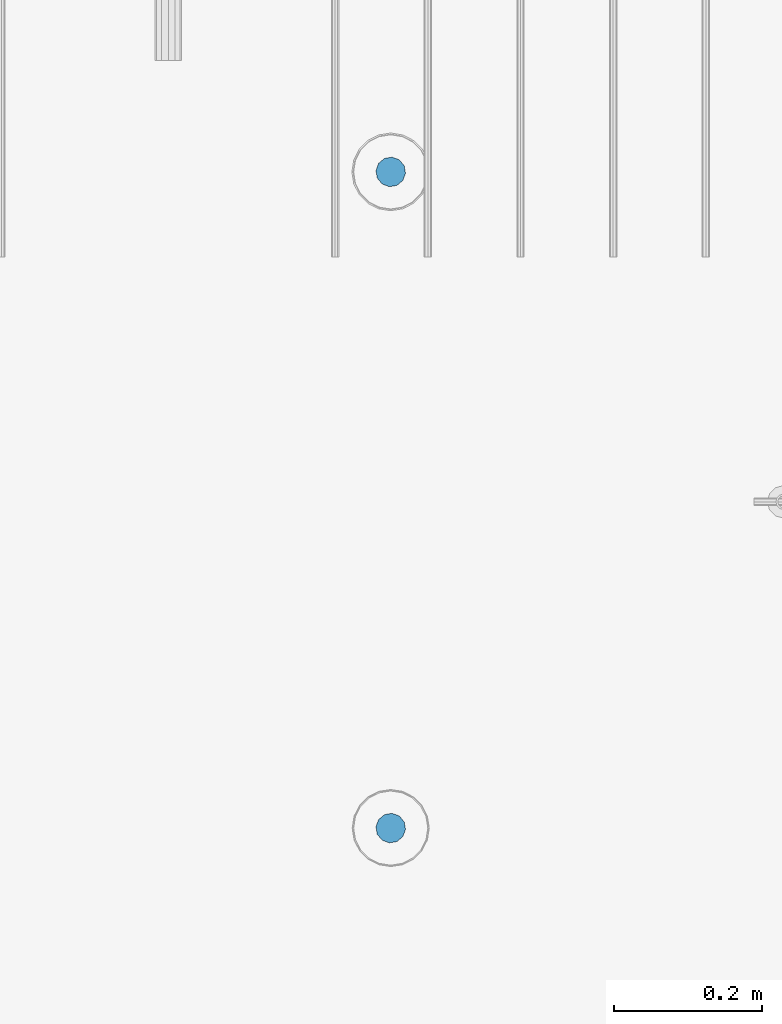
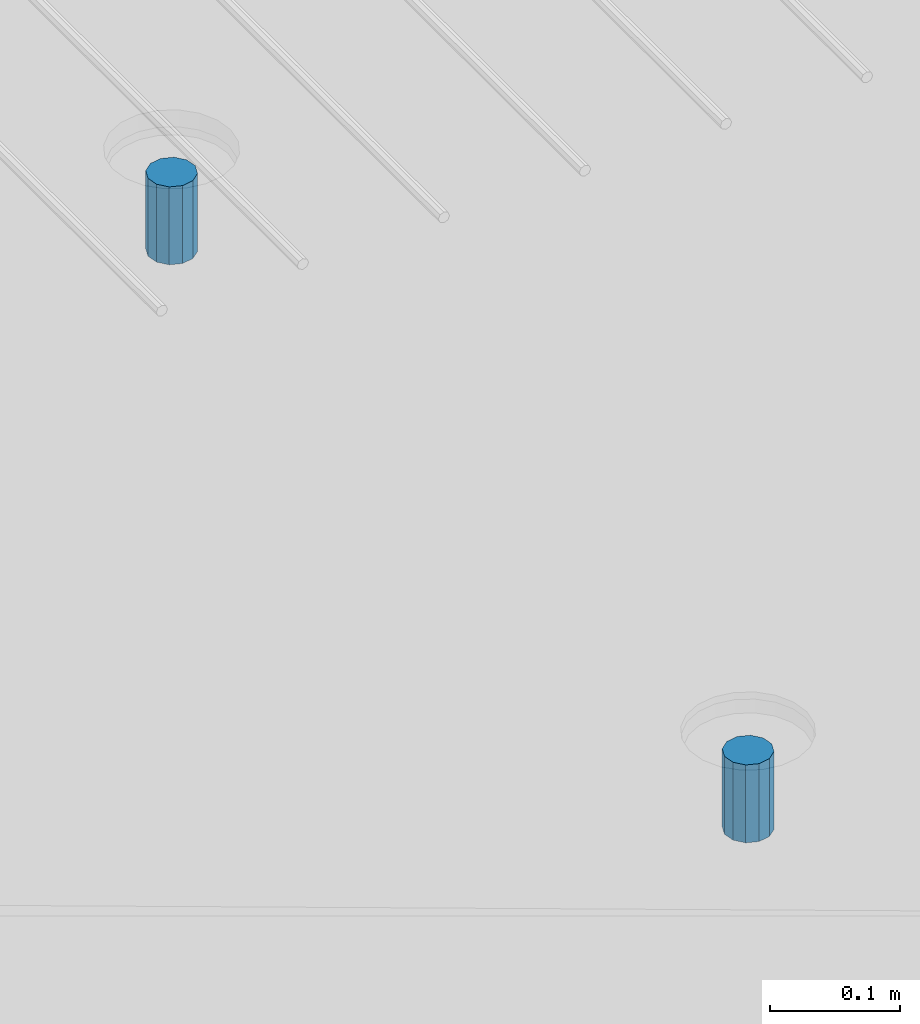
# One storey, part 52 of 350: 2 columns, 3 elements without a shape of their own.
"""IFC2X3 building model written with IfcOpenShell, lengths in millimetres."""

from ifc_helpers import new_model, si_unit, frame, origin_with_axes, place, context, subcontext, project, spatial, faceted_brep, material, type_object, element, aggregate, save


model = new_model("IFC2X3")

# Units and contexts
model_context = context("Model", 3, precision=1e-05, world=origin_with_axes())
body_context = subcontext(model_context, "Body", "Model", "MODEL_VIEW")
ifc_project = project(units=[si_unit("LENGTHUNIT", "METRE", prefix="MILLI"), si_unit("AREAUNIT", "SQUARE_METRE"), si_unit("VOLUMEUNIT", "CUBIC_METRE"), si_unit("MASSUNIT", "GRAM", prefix="KILO"), si_unit("TIMEUNIT", "SECOND"), si_unit("PLANEANGLEUNIT", "RADIAN"), si_unit("SOLIDANGLEUNIT", "STERADIAN"), si_unit("THERMODYNAMICTEMPERATUREUNIT", "DEGREE_CELSIUS"), si_unit("LUMINOUSINTENSITYUNIT", "LUMEN")], contexts=[model_context])

# Site, building, storey
site_placement = place(None, origin_with_axes())
site = spatial("IfcSite", under=ifc_project, at=site_placement, CompositionType="ELEMENT")
building_placement = place(site_placement, origin_with_axes())
building = spatial("IfcBuilding", under=site, at=building_placement, CompositionType="ELEMENT")
storey_placement = place(building_placement, origin_with_axes())
storey = spatial("IfcBuildingStorey", under=building, at=storey_placement, Name="2", CompositionType="ELEMENT", Elevation=0.0)

# Assemblies, columns
assembly_1_placement = place(storey_placement, origin_with_axes())
assembly_1 = element("IfcElementAssembly", 1, at=assembly_1_placement, inside=storey, AssemblyPlace="NOTDEFINED", PredefinedType="REINFORCEMENT_UNIT")
assembly_2_placement = place(assembly_1_placement, origin_with_axes())
assembly_2 = element("IfcElementAssembly", 2, at=assembly_2_placement, Name="Steel Assembly", AssemblyPlace="NOTDEFINED", PredefinedType="RIGID_FRAME")
ifc_material = material(Name="STEEL/Steel_Undefined")
column_type = type_object("IfcColumnType", Name="D40", PredefinedType="NOTDEFINED")
column_1_placement = place(assembly_2_placement, frame((29319.9998566724, 6144.99747289933, 87625.0000000001), z_axis=(0.418944694779052, -0.908011752521126, 0.0), x_axis=(0.0, 0.0, 1.0)))
column_1 = element("IfcColumn", 3, at=column_1_placement, type_object=column_type, material=ifc_material, Name="R-Group R", ObjectType="D40", context=body_context, shape_type="Brep", body=[
    faceted_brep([(0.0, -20.0, 0.0), (0.0, -17.3205080756888, -10.0), (73.0, -17.3205080756852, -9.99999999999636), (73.0, -19.9999999999964, 3.63797880709171e-12), (0.0, -10.0, -17.3205080756888), (73.0, -10.0, -17.3205080756834), (0.0, 0.0, -20.0), (73.0, 3.63797880709171e-12, -19.9999999999964), (0.0, 10.0, -17.3205080756888), (73.0, 10.0000000000036, -17.3205080756834), (0.0, 17.3205080756888, -10.0), (73.0, 17.3205080756925, -9.99999999999818), (0.0, 20.0, 0.0), (73.0, 20.0, 3.63797880709171e-12), (0.0, 17.3205080756888, 10.0), (73.0, 17.3205080756888, 10.0000000000036), (0.0, 10.0, 17.3205080756888), (73.0, 10.0000000000036, 17.3205080756961), (0.0, 0.0, 20.0), (73.0, 3.63797880709171e-12, 20.0000000000036), (0.0, -10.0, 17.3205080756888), (73.0, -9.99999999999636, 17.3205080756925), (0.0, -17.3205080756888, 10.0), (73.0, -17.3205080756852, 10.0000000000055)], [[[0, 1, 2, 3]], [[1, 4, 5, 2]], [[4, 6, 7, 5]], [[6, 8, 9, 7]], [[8, 10, 11, 9]], [[10, 12, 13, 11]], [[12, 14, 15, 13]], [[14, 16, 17, 15]], [[16, 18, 19, 17]], [[18, 20, 21, 19]], [[20, 22, 23, 21]], [[22, 0, 3, 23]], [[5, 7, 9, 11, 13, 15, 17, 19, 21, 23, 3, 2]], [[22, 20, 18, 16, 14, 12, 10, 8, 6, 4, 1, 0]]]),
])
aggregate(assembly_2, [column_1])
assembly_3_placement = place(assembly_1_placement, origin_with_axes())
assembly_3 = element("IfcElementAssembly", 4, at=assembly_3_placement, Name="Steel Assembly", AssemblyPlace="NOTDEFINED", PredefinedType="RIGID_FRAME")
aggregate(assembly_1, [assembly_2, assembly_3])
column_2_placement = place(assembly_3_placement, frame((29319.9998566724, 7029.99747289932, 87630.0000000001), z_axis=(0.418944694779052, -0.908011752521126, 0.0), x_axis=(0.0, 0.0, 1.0)))
column_2 = element("IfcColumn", 5, at=column_2_placement, type_object=column_type, material=ifc_material, Name="R-Group R", ObjectType="D40", context=body_context, shape_type="Brep", body=[
    faceted_brep([(0.0, -20.0, 0.0), (0.0, -17.3205080756888, -10.0), (73.0, -17.3205080756852, -9.99999999999636), (73.0, -19.9999999999964, 3.63797880709171e-12), (0.0, -10.0, -17.3205080756888), (73.0, -10.0, -17.3205080756834), (0.0, 0.0, -20.0), (73.0, 3.63797880709171e-12, -19.9999999999964), (0.0, 10.0, -17.3205080756888), (73.0, 10.0000000000036, -17.3205080756834), (0.0, 17.3205080756888, -10.0), (73.0, 17.3205080756925, -9.99999999999818), (0.0, 20.0, 0.0), (73.0, 20.0, 3.63797880709171e-12), (0.0, 17.3205080756888, 10.0), (73.0, 17.3205080756888, 10.0000000000036), (0.0, 10.0, 17.3205080756888), (73.0, 10.0000000000036, 17.3205080756961), (0.0, 0.0, 20.0), (73.0, 3.63797880709171e-12, 20.0000000000036), (0.0, -10.0, 17.3205080756888), (73.0, -9.99999999999636, 17.3205080756925), (0.0, -17.3205080756888, 10.0), (73.0, -17.3205080756852, 10.0000000000055)], [[[0, 1, 2, 3]], [[1, 4, 5, 2]], [[4, 6, 7, 5]], [[6, 8, 9, 7]], [[8, 10, 11, 9]], [[10, 12, 13, 11]], [[12, 14, 15, 13]], [[14, 16, 17, 15]], [[16, 18, 19, 17]], [[18, 20, 21, 19]], [[20, 22, 23, 21]], [[22, 0, 3, 23]], [[5, 7, 9, 11, 13, 15, 17, 19, 21, 23, 3, 2]], [[22, 20, 18, 16, 14, 12, 10, 8, 6, 4, 1, 0]]]),
])
aggregate(assembly_3, [column_2])

save(model, "model.ifc")
